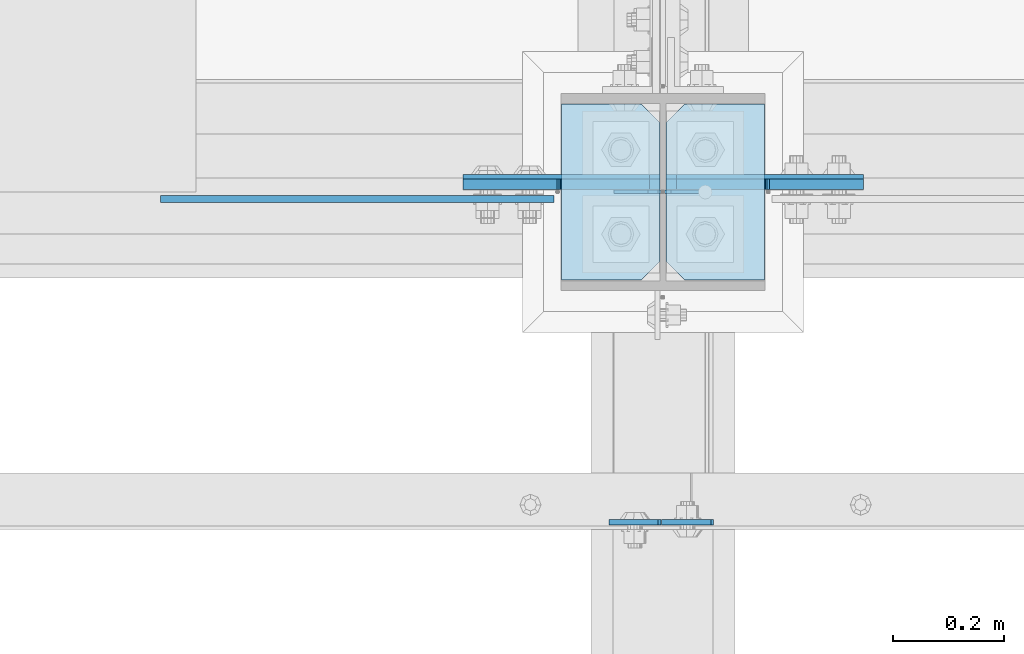
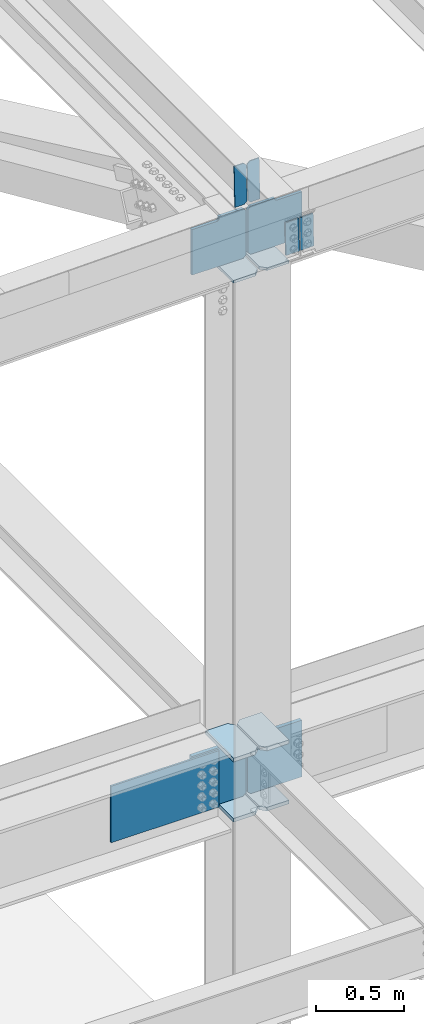
# One storey, part 3189 of 3843: 15 plates, 3 elements without a shape of their own.
"""IFC2X3 building model written with IfcOpenShell, lengths in millimetres."""

from ifc_helpers import new_model, si_unit, frame, origin_with_axes, place, context, subcontext, project, spatial, faceted_brep, material, type_object, element, aggregate, save


model = new_model("IFC2X3")

# Units and contexts
model_context = context("Model", 3, precision=1e-05, world=origin_with_axes())
body_context = subcontext(model_context, "Body", "Model", "MODEL_VIEW")
ifc_project = project(units=[si_unit("LENGTHUNIT", "METRE", prefix="MILLI"), si_unit("AREAUNIT", "SQUARE_METRE"), si_unit("VOLUMEUNIT", "CUBIC_METRE"), si_unit("MASSUNIT", "GRAM", prefix="KILO"), si_unit("TIMEUNIT", "SECOND"), si_unit("PLANEANGLEUNIT", "RADIAN"), si_unit("SOLIDANGLEUNIT", "STERADIAN"), si_unit("THERMODYNAMICTEMPERATUREUNIT", "DEGREE_CELSIUS"), si_unit("LUMINOUSINTENSITYUNIT", "LUMEN")], contexts=[model_context])

# Site, building, storey
site_placement = place(None, origin_with_axes())
site = spatial("IfcSite", under=ifc_project, at=site_placement, CompositionType="ELEMENT")
building_placement = place(site_placement, origin_with_axes())
building = spatial("IfcBuilding", under=site, at=building_placement, Name="Undefined", CompositionType="ELEMENT")
storey_placement = place(building_placement, origin_with_axes())
storey = spatial("IfcBuildingStorey", under=building, at=storey_placement, Name="Undefined", CompositionType="ELEMENT", Elevation=0.0)

# Assembly, plates
assembly_1_placement = place(storey_placement, origin_with_axes())
assembly_1 = element("IfcElementAssembly", 1, at=assembly_1_placement, inside=storey, Name="COLUMN", AssemblyPlace="NOTDEFINED", PredefinedType="RIGID_FRAME")
ifc_material = material(Name="STEEL/A572-50")
plate_type_1 = type_object("IfcPlateType", PredefinedType="NOTDEFINED")
plate_1_placement = place(assembly_1_placement, frame((70439.75625, 25457.15, 42005.249987793), z_axis=(0.0, 1.0, 0.0), x_axis=(-1.0, 0.0, 0.0)))
plate_1 = element("IfcPlate", 2, at=plate_1_placement, type_object=plate_type_1, material=ifc_material, Name="PLATE", context=body_context, shape_type="Brep", body=[
    faceted_brep([(0.0, -12.6999999999971, 0.0), (0.0, -12.7000000020344, 317.500000001608), (0.0, 12.6999999977998, 317.500000001586), (0.0, 12.6999999999971, 0.0), (144.462501525879, -12.6999999999971, 317.5), (144.462501525879, 12.6999999999971, 317.5), (177.800003051758, -12.6999999999971, 284.162498474121), (177.800003051758, 12.6999999999971, 284.162498474121), (177.800003051758, -12.6999999999971, 33.3375015258789), (177.800003051758, 12.6999999999971, 33.3375015258789), (144.462501525879, -12.6999999999971, 0.0), (144.462501525879, 12.6999999999971, 0.0)], [[[0, 1, 2, 3]], [[1, 4, 5, 2]], [[4, 6, 7, 5]], [[6, 8, 9, 7]], [[8, 10, 11, 9]], [[10, 0, 3, 11]], [[5, 7, 9, 11, 3, 2]], [[10, 8, 6, 4, 1, 0]]]),
])
plate_2_placement = place(assembly_1_placement, frame((70439.75625, 25457.15, 42424.35), z_axis=(0.0, 1.0, 0.0), x_axis=(-1.0, 0.0, 0.0)))
plate_2 = element("IfcPlate", 3, at=plate_2_placement, type_object=plate_type_1, material=ifc_material, Name="PLATE", context=body_context, shape_type="Brep", body=[
    faceted_brep([(0.0, -12.6999999999971, 0.0), (0.0, -12.7000000020344, 317.500000001608), (0.0, 12.6999999977998, 317.500000001586), (0.0, 12.6999999999971, 0.0), (144.462501525879, -12.6999999999971, 317.5), (144.462501525879, 12.6999999999971, 317.5), (177.800003051758, -12.6999999999971, 284.162498474121), (177.800003051758, 12.6999999999971, 284.162498474121), (177.800003051758, -12.6999999999971, 33.3375015258789), (177.800003051758, 12.6999999999971, 33.3375015258789), (144.462501525879, -12.6999999999971, 0.0), (144.462501525879, 12.6999999999971, 0.0)], [[[0, 1, 2, 3]], [[1, 4, 5, 2]], [[4, 6, 7, 5]], [[6, 8, 9, 7]], [[8, 10, 11, 9]], [[10, 0, 3, 11]], [[5, 7, 9, 11, 3, 2]], [[10, 8, 6, 4, 1, 0]]]),
])
plate_3_placement = place(assembly_1_placement, frame((70073.04375, 25774.65, 42005.249987793), z_axis=(0.0, -1.0, 0.0), x_axis=(1.0, 0.0, 0.0)))
plate_3 = element("IfcPlate", 4, at=plate_3_placement, type_object=plate_type_1, material=ifc_material, Name="PLATE", context=body_context, shape_type="Brep", body=[
    faceted_brep([(0.0, -12.6999999999971, 0.0), (0.0, -12.7000000020344, 317.500000001608), (0.0, 12.6999999977998, 317.500000001586), (0.0, 12.6999999999971, 0.0), (144.462501525879, -12.6999999999971, 317.5), (144.462501525879, 12.6999999999971, 317.5), (177.800003051758, -12.6999999999971, 284.162498474121), (177.800003051758, 12.6999999999971, 284.162498474121), (177.800003051758, -12.6999999999971, 33.3375015258789), (177.800003051758, 12.6999999999971, 33.3375015258789), (144.462501525879, -12.6999999999971, 0.0), (144.462501525879, 12.6999999999971, 0.0)], [[[0, 1, 2, 3]], [[1, 4, 5, 2]], [[4, 6, 7, 5]], [[6, 8, 9, 7]], [[8, 10, 11, 9]], [[10, 0, 3, 11]], [[5, 7, 9, 11, 3, 2]], [[10, 8, 6, 4, 1, 0]]]),
])
plate_4_placement = place(assembly_1_placement, frame((70073.04375, 25774.65, 42424.35), z_axis=(0.0, -1.0, 0.0), x_axis=(1.0, 0.0, 0.0)))
plate_4 = element("IfcPlate", 5, at=plate_4_placement, type_object=plate_type_1, material=ifc_material, Name="PLATE", context=body_context, shape_type="Brep", body=[
    faceted_brep([(0.0, -12.6999999999971, 0.0), (0.0, -12.7000000020344, 317.500000001608), (0.0, 12.6999999977998, 317.500000001586), (0.0, 12.6999999999971, 0.0), (144.462501525879, -12.6999999999971, 317.5), (144.462501525879, 12.6999999999971, 317.5), (177.800003051758, -12.6999999999971, 284.162498474121), (177.800003051758, 12.6999999999971, 284.162498474121), (177.800003051758, -12.6999999999971, 33.3375015258789), (177.800003051758, 12.6999999999971, 33.3375015258789), (144.462501525879, -12.6999999999971, 0.0), (144.462501525879, 12.6999999999971, 0.0)], [[[0, 1, 2, 3]], [[1, 4, 5, 2]], [[4, 6, 7, 5]], [[6, 8, 9, 7]], [[8, 10, 11, 9]], [[10, 0, 3, 11]], [[5, 7, 9, 11, 3, 2]], [[10, 8, 6, 4, 1, 0]]]),
])
plate_type_2 = type_object("IfcPlateType", PredefinedType="NOTDEFINED")
plate_5_placement = place(assembly_1_placement, frame((70261.95625, 25634.9499999046, 42411.65), z_axis=(1.0, 0.0, 0.0), x_axis=(0.0, 0.0, -1.0)))
plate_5 = element("IfcPlate", 6, at=plate_5_placement, type_object=plate_type_2, material=ifc_material, Name="PLATE", context=body_context, shape_type="Brep", body=[
    faceted_brep([(0.0, -12.6999999999971, 19.0499992370605), (0.0, -12.6999999999971, 356.393737792969), (0.0, 12.6999999999971, 356.393737792969), (0.0, 12.6999999999971, 19.0499992370605), (393.700012207031, -12.6999999999971, 356.393737792969), (393.700012207031, 12.6999999999971, 356.393737792969), (393.700012207031, -12.6999999999971, 19.0499992370605), (393.700012207031, 12.6999999999971, 19.0499992370605), (374.650012969971, -12.6999999999971, 0.0), (374.650012969971, 12.6999999999971, 0.0), (19.0500015258731, -12.6999999999971, -6.33008312433958e-10), (19.0500015258731, 12.6999999999971, 0.0)], [[[0, 1, 2, 3]], [[1, 4, 5, 2]], [[4, 6, 7, 5]], [[6, 8, 9, 7]], [[8, 10, 11, 9]], [[10, 0, 3, 11]], [[5, 7, 9, 11, 3, 2]], [[10, 8, 6, 4, 1, 0]]]),
])
plate_6_placement = place(assembly_1_placement, frame((70250.84375, 25634.9499999046, 42411.65), z_axis=(-1.0, 0.0, 0.0), x_axis=(0.0, 0.0, -1.0)))
plate_6 = element("IfcPlate", 7, at=plate_6_placement, type_object=plate_type_2, material=ifc_material, Name="PLATE", context=body_context, shape_type="Brep", body=[
    faceted_brep([(0.0, -12.6999999999971, 19.0499992370605), (0.0, -12.6999999999971, 356.393737792969), (0.0, 12.6999999999971, 356.393737792969), (0.0, 12.6999999999971, 19.0499992370605), (393.700012207031, -12.6999999999971, 356.393737792969), (393.700012207031, 12.6999999999971, 356.393737792969), (393.700012207031, -12.6999999999971, 19.0499992370605), (393.700012207031, 12.6999999999971, 19.0499992370605), (374.650012969971, -12.6999999999971, 0.0), (374.650012969971, 12.6999999999971, 0.0), (19.0500015258731, -12.6999999999971, -6.33008312433958e-10), (19.0500015258731, 12.6999999999971, 0.0)], [[[0, 1, 2, 3]], [[1, 4, 5, 2]], [[4, 6, 7, 5]], [[6, 8, 9, 7]], [[8, 10, 11, 9]], [[10, 0, 3, 11]], [[5, 7, 9, 11, 3, 2]], [[10, 8, 6, 4, 1, 0]]]),
])

assembly_2_placement = place(storey_placement, origin_with_axes())
assembly_2 = element("IfcElementAssembly", 8, at=assembly_2_placement, inside=storey, Name="BEAM", AssemblyPlace="NOTDEFINED", PredefinedType="RIGID_FRAME")
plate_type_3 = type_object("IfcPlateType", PredefinedType="NOTDEFINED")
plate_7_placement = place(assembly_2_placement, frame((70253.7993978729, 25019.0000000872, 46404.0016309718), z_axis=(0.999776270257024, 0.0, 0.0211520550054619), x_axis=(0.0211520550054438, 0.0, -0.999776270257025)))
plate_7 = element("IfcPlate", 9, at=plate_7_placement, type_object=plate_type_3, material=ifc_material, Name="PLATE", context=body_context, shape_type="Brep", body=[
    faceted_brep([(0.0, -4.76249999999709, 0.0), (0.0, -4.76249999999709, 88.9000015258789), (0.0, 4.76249999999709, 88.9000015258789), (0.0, 4.76249999999709, 0.0), (228.600006102781, -4.7625000004191, 88.9000015257589), (228.600006102781, 4.76249999954598, 88.9000015257443), (228.600006103079, -4.7625000004482, 7.27595761418343e-12), (228.600006103079, 4.76249999954598, -7.27595761418343e-12)], [[[0, 1, 2, 3]], [[1, 4, 5, 2]], [[4, 6, 7, 5]], [[6, 0, 3, 7]], [[5, 7, 3, 2]], [[6, 4, 1, 0]]]),
])
plate_8_placement = place(assembly_2_placement, frame((70247.4504483151, 25019.0000000415, 46403.8673040873), z_axis=(-0.999776270257024, 0.0, -0.0211520550054595), x_axis=(0.0211520550054438, 0.0, -0.999776270257025)))
plate_8 = element("IfcPlate", 10, at=plate_8_placement, type_object=plate_type_3, material=ifc_material, Name="PLATE", context=body_context, shape_type="Brep", body=[
    faceted_brep([(0.0, -4.76249999999709, 0.0), (0.0, -4.76249999999709, 88.9000015258789), (0.0, 4.76249999999709, 88.9000015258789), (0.0, 4.76249999999709, 0.0), (228.600006102781, -4.7625000004191, 88.9000015257589), (228.600006102781, 4.76249999954598, 88.9000015257443), (228.600006103079, -4.7625000004482, 7.27595761418343e-12), (228.600006103079, 4.76249999954598, -7.27595761418343e-12)], [[[0, 1, 2, 3]], [[1, 4, 5, 2]], [[4, 6, 7, 5]], [[6, 0, 3, 7]], [[5, 7, 3, 2]], [[6, 4, 1, 0]]]),
])
plate_type_4 = type_object("IfcPlateType", PredefinedType="NOTDEFINED")
plate_9_placement = place(assembly_2_placement, frame((70338.6964782617, 25616.5918725847, 46144.9236657613), z_axis=(-0.0211520977514447, -0.0018380119996873, 0.999774579829175), x_axis=(-0.999776269352655, 3.88860000353947e-05, -0.0211520620074247)))
plate_9 = element("IfcPlate", 11, at=plate_9_placement, type_object=plate_type_4, material=ifc_material, Name="STIFFENER", context=body_context, shape_type="Brep", body=[
    faceted_brep([(0.0, -3.17499999999927, 0.0), (6.83940015733242e-10, -3.17499999996653, 288.924999998613), (6.54836185276508e-10, 3.17500000001746, 288.924999998591), (0.0, 3.17499999999927, 0.0), (61.9125003828667, -3.17499999997744, 288.924999998599), (61.9125003828522, 3.17500000002838, 288.924999998584), (79.3750000013097, -3.17499999997744, 271.462500380039), (79.375000001266, 3.17500000002838, 271.462500380017), (79.375000000713, -3.17499999999927, 17.4624996185448), (79.3750000006694, 3.17500000000291, 17.462499618523), (61.9125003821828, -3.17499999999563, -1.45519152283669e-11), (61.9125003821682, 3.17500000000655, -2.91038304567337e-11)], [[[0, 1, 2, 3]], [[1, 4, 5, 2]], [[4, 6, 7, 5]], [[6, 8, 9, 7]], [[8, 10, 11, 9]], [[10, 0, 3, 11]], [[5, 7, 9, 11, 3, 2]], [[10, 8, 6, 4, 1, 0]]]),
])
plate_10_placement = place(assembly_2_placement, frame((70252.9906575714, 25616.5952061306, 46143.1104052247), z_axis=(-0.0211520977514447, -0.0018380119996873, 0.999774579829175), x_axis=(-0.999776269352655, 3.88860000353947e-05, -0.0211520620074247)))
plate_10 = element("IfcPlate", 12, at=plate_10_placement, type_object=plate_type_4, material=ifc_material, Name="STIFFENER", context=body_context, shape_type="Brep", body=[
    faceted_brep([(5.82076609134674e-11, -3.17499999999927, 17.4624996185667), (6.25732354819775e-10, -3.17499999997744, 271.462500380054), (5.82076609134674e-10, 3.17500000002474, 271.462500380039), (0.0, 3.17500000000655, 17.4624996185521), (17.462499619156, -3.17499999997744, 288.924999998606), (17.4624996191269, 3.17500000002474, 288.924999998591), (79.3750000013242, -3.17500000025029, 288.924999998591), (79.3750000013097, 3.1749999997337, 288.92499999857), (79.3750000006548, -3.17500000026484, -2.18278728425503e-11), (79.3750000006403, 3.17499999969732, -2.91038304567337e-11), (17.4624996184866, -3.17500000000291, 7.27595761418343e-12), (17.462499618443, 3.17500000000291, -7.27595761418343e-12)], [[[0, 1, 2, 3]], [[1, 4, 5, 2]], [[4, 6, 7, 5]], [[6, 8, 9, 7]], [[8, 10, 11, 9]], [[10, 0, 3, 11]], [[5, 7, 9, 11, 3, 2]], [[10, 8, 6, 4, 1, 0]]]),
])
aggregate(assembly_2, [plate_7, plate_8, plate_9, plate_10])

# Plate
plate_type_5 = type_object("IfcPlateType", PredefinedType="NOTDEFINED")
plate_11_placement = place(assembly_1_placement, frame((70439.75625, 25457.15, 45765.129706899), z_axis=(0.0, 1.0, 0.0), x_axis=(-1.0, 0.0, 0.0)))
plate_11 = element("IfcPlate", 13, at=plate_11_placement, type_object=plate_type_5, material=ifc_material, Name="PLATE", context=body_context, shape_type="Brep", body=[
    faceted_brep([(0.0, -9.52500000000146, 0.0), (0.0, -9.52500000000146, 317.5), (0.0, 9.52500000000146, 317.5), (0.0, 9.52500000000146, 0.0), (144.462501525879, -9.52500000000146, 317.5), (144.462501525879, 9.52500000000146, 317.5), (177.800003051758, -9.52500000000146, 284.162498474121), (177.800003051758, 9.52500000000146, 284.162498474121), (177.800003051758, -9.52500000000146, 33.3375015258789), (177.800003051758, 9.52500000000146, 33.3375015258789), (144.462501525879, -9.52500000000146, 0.0), (144.462501525879, 9.52500000000146, 0.0)], [[[0, 1, 2, 3]], [[1, 4, 5, 2]], [[4, 6, 7, 5]], [[6, 8, 9, 7]], [[8, 10, 11, 9]], [[10, 0, 3, 11]], [[5, 7, 9, 11, 3, 2]], [[10, 8, 6, 4, 1, 0]]]),
])

plate_12_placement = place(assembly_1_placement, frame((70073.0437499884, 25774.6499999999, 45753.6252590546), z_axis=(0.0, -1.0, 0.0), x_axis=(1.0, 0.0, 0.0)))
plate_12 = element("IfcPlate", 14, at=plate_12_placement, type_object=plate_type_5, material=ifc_material, Name="PLATE", context=body_context, shape_type="Brep", body=[
    faceted_brep([(0.0, -9.52500000000146, 0.0), (0.0, -9.52500000000146, 317.5), (0.0, 9.52500000000146, 317.5), (0.0, 9.52500000000146, 0.0), (144.462501525879, -9.52500000000146, 317.5), (144.462501525879, 9.52500000000146, 317.5), (177.800003051758, -9.52500000000146, 284.162498474121), (177.800003051758, 9.52500000000146, 284.162498474121), (177.800003051758, -9.52500000000146, 33.3375015258789), (177.800003051758, 9.52500000000146, 33.3375015258789), (144.462501525879, -9.52500000000146, 0.0), (144.462501525879, 9.52500000000146, 0.0)], [[[0, 1, 2, 3]], [[1, 4, 5, 2]], [[4, 6, 7, 5]], [[6, 8, 9, 7]], [[8, 10, 11, 9]], [[10, 0, 3, 11]], [[5, 7, 9, 11, 3, 2]], [[10, 8, 6, 4, 1, 0]]]),
])

# Assembly, plate
assembly_3_placement = place(storey_placement, origin_with_axes())
assembly_3 = element("IfcElementAssembly", 15, at=assembly_3_placement, inside=storey, Name="BEAM", AssemblyPlace="NOTDEFINED", PredefinedType="RIGID_FRAME")
plate_type_6 = type_object("IfcPlateType", PredefinedType="NOTDEFINED")
plate_13_placement = place(assembly_3_placement, frame((70059.55, 25603.2000000001, 42017.949987793), z_axis=(0.0, 0.0, 1.0), x_axis=(-1.0, 0.0, 0.0)))
plate_13 = element("IfcPlate", 16, at=plate_13_placement, type_object=plate_type_6, material=ifc_material, Name="PLATE", context=body_context, shape_type="Brep", body=[
    faceted_brep([(0.0, -6.3499999046162, 0.0), (0.0, -6.34999999999854, 393.700012207031), (0.0, 6.34999999999854, 393.700012207031), (7.27595761418343e-12, 6.3499999046162, 0.0), (711.199999999968, -6.35000000000582, 393.700012207031), (711.200000000012, 6.34999999999854, 393.700000000004), (711.199999999968, -6.35000000000582, 0.0), (711.199999999997, 6.34999999999854, 0.0)], [[[0, 1, 2, 3]], [[1, 4, 5, 2]], [[4, 6, 7, 5]], [[6, 0, 3, 7]], [[7, 3, 2, 5]], [[6, 4, 1, 0]]]),
])
aggregate(assembly_3, [plate_13])

# Plate
plate_type_7 = type_object("IfcPlateType", PredefinedType="NOTDEFINED")
plate_14_placement = place(assembly_1_placement, frame((70261.95625, 25630.1875003815, 45793.7047068728), z_axis=(0.707106781186548, 0.0, 0.707106781186548), x_axis=(0.707106781186548, 0.0, -0.707106781186548)))
plate_14 = element("IfcPlate", 17, at=plate_14_placement, type_object=plate_type_7, material=ifc_material, Name="PLATE", context=body_context, shape_type="Brep", body=[
    faceted_brep([(0.0, -9.52500000000146, 0.0), (-209.979301496754, -9.52500000000146, 209.979301496671), (-209.979301496754, 9.52500000000146, 209.979301496671), (0.0, 9.52500000000146, 0.0), (-209.979301496471, -9.52500000000146, 236.920069860033), (-209.979301496471, 9.52500000000146, 236.920069860033), (-97.1648339737767, -9.52500000000146, 349.734537382756), (-97.1648339737767, 9.52500000000146, 349.734537382756), (-93.3396839560301, -9.52500000000146, 345.909387365013), (-93.3396839560301, 9.52500000000146, 345.909387365013), (-89.219507487891, -9.52500000000146, 343.156373464546), (-89.219507487891, 9.52500000000146, 343.156373464546), (-84.35942796983, -9.52500000000146, 342.189643541991), (-84.35942796983, 9.52500000000146, 342.189643541991), (-79.4993484517727, -9.52500000000146, 343.15637346459), (-79.4993484517727, 9.52500000000146, 343.15637346459), (-75.3791719835863, -9.52500000000146, 345.909387365115), (-75.3791719835863, 9.52500000000146, 345.909387365115), (41.3641577270682, -9.52500000000146, 462.652717075805), (41.3641577270682, 9.52500000000146, 462.652717075805), (265.870560752759, -9.52500000000146, 238.146314050202), (265.870560752759, 9.52500000000146, 238.146314050202), (26.9407683632344, -9.52499999999964, 2.03726813197136e-10), (26.9407683632344, 9.52499999999964, 2.03726813197136e-10)], [[[0, 1, 2, 3]], [[1, 4, 5, 2]], [[4, 6, 7, 5]], [[6, 8, 9, 7]], [[8, 10, 11, 9]], [[10, 12, 13, 11]], [[12, 14, 15, 13]], [[14, 16, 17, 15]], [[16, 18, 19, 17]], [[18, 20, 21, 19]], [[20, 22, 23, 21]], [[22, 0, 3, 23]], [[5, 7, 9, 11, 13, 15, 17, 19, 21, 23, 3, 2]], [[22, 20, 18, 16, 14, 12, 10, 8, 6, 4, 1, 0]]]),
])

plate_type_8 = type_object("IfcPlateType", PredefinedType="NOTDEFINED")
plate_15_placement = place(assembly_1_placement, frame((70250.8437499999, 25630.1875003815, 45782.2002589413), z_axis=(-0.707106781186548, 0.0, 0.707106781186548), x_axis=(-0.707106781186548, 0.0, -0.707106781186548)))
plate_15 = element("IfcPlate", 18, at=plate_15_placement, type_object=plate_type_8, material=ifc_material, Name="PLATE", context=body_context, shape_type="Brep", body=[
    faceted_brep([(0.0, -9.52500000000146, 0.0), (-217.83702560261, -9.52500000000146, 217.837025602606), (-217.83702560261, 9.52500000000146, 217.837025602606), (0.0, 9.52500000000146, 0.0), (-217.837025602319, -9.52500000000146, 244.777793965968), (-217.837025602319, 9.52500000000146, 244.777793965968), (-105.02255807961, -9.52500000000146, 357.592261488677), (-105.02255807961, 9.52500000000146, 357.592261488677), (-94.254791630985, -9.52500000000146, 346.824495040062), (-94.254791630985, 9.52500000000146, 346.824495040062), (-90.1346151628532, -9.52500000000146, 344.071481139596), (-90.1346151628532, 9.52500000000146, 344.071481139596), (-85.2745356447995, -9.52500000000146, 343.104751217026), (-85.2745356447995, 9.52500000000146, 343.104751217026), (-80.4144561267167, -9.52500000000146, 344.07148113965), (-80.4144561267167, 9.52500000000146, 344.07148113965), (-76.2942796585558, -9.52500000000146, 346.824495040149), (-76.2942796585558, 9.52500000000146, 346.824495040149), (40.4490500521206, -9.52500000000146, 463.567824750826), (40.4490500521206, 9.52500000000146, 463.567824750826), (264.955453077768, -9.52500000000146, 239.061421725179), (264.955453077768, 9.52500000000146, 239.061421725179), (26.9407683632344, -9.52499999999964, 2.03726813197136e-10), (26.9407683632344, 9.52499999999964, 2.03726813197136e-10)], [[[0, 1, 2, 3]], [[1, 4, 5, 2]], [[4, 6, 7, 5]], [[6, 8, 9, 7]], [[8, 10, 11, 9]], [[10, 12, 13, 11]], [[12, 14, 15, 13]], [[14, 16, 17, 15]], [[16, 18, 19, 17]], [[18, 20, 21, 19]], [[20, 22, 23, 21]], [[22, 0, 3, 23]], [[5, 7, 9, 11, 13, 15, 17, 19, 21, 23, 3, 2]], [[22, 20, 18, 16, 14, 12, 10, 8, 6, 4, 1, 0]]]),
])

aggregate(assembly_1, [plate_1, plate_2, plate_5, plate_3, plate_4, plate_6, plate_11, plate_14, plate_12, plate_15])

save(model, "model.ifc")
